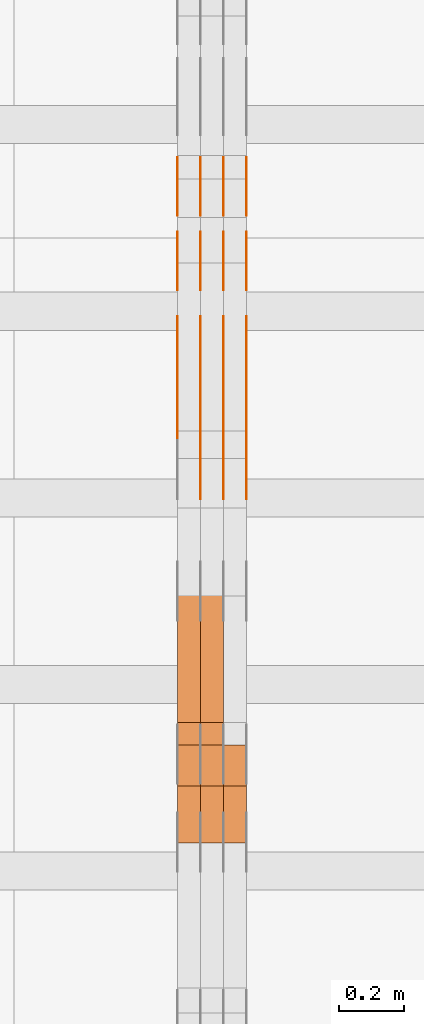
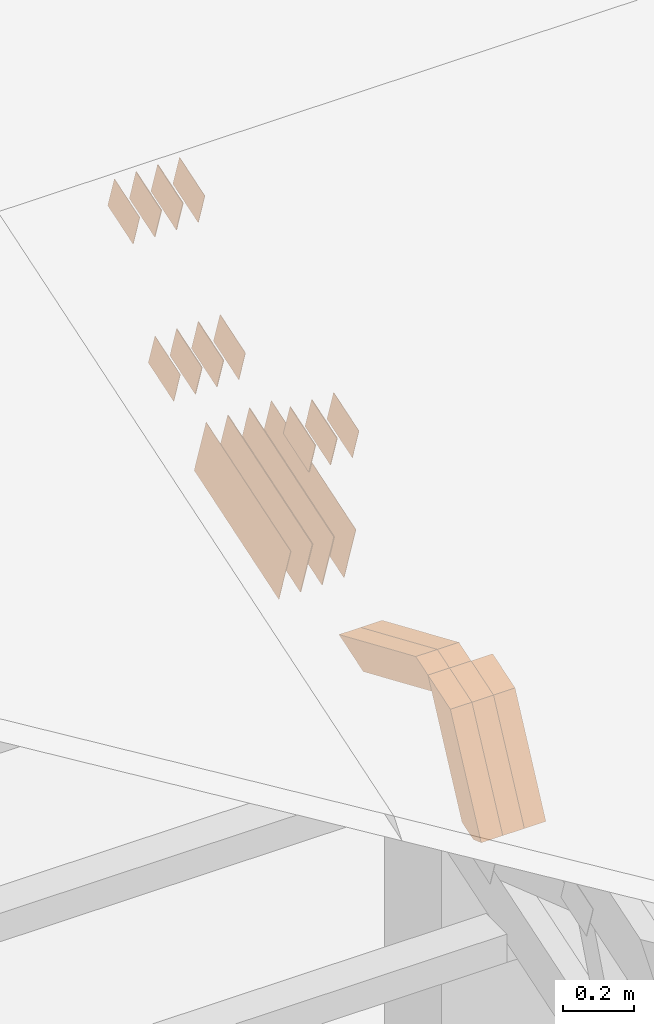
# One storey, part 132 of 385: 28 proxies.
"""IFC2X3 building model written with IfcOpenShell, lengths in millimetres."""

from ifc_helpers import new_model, entity, si_unit, converted_unit, derived_unit, direction, frame, origin, place, context, subcontext, project, spatial, polyline, outline, extrude, source, transform, mapped, material, type_object, type_shapes, element, save


model = new_model("IFC2X3")

# Units and contexts
model_context = context("Model", 3, precision=0.01, world=origin(), true_north=direction((6.12303176911189e-17, 1.0)))
body_context = subcontext(model_context, "Body", "Model", "MODEL_VIEW")
ifc_project = project(units=[si_unit("LENGTHUNIT", "METRE", prefix="MILLI"), si_unit("AREAUNIT", "SQUARE_METRE"), si_unit("VOLUMEUNIT", "CUBIC_METRE"), converted_unit("PLANEANGLEUNIT", "DEGREE", entity("IfcRatioMeasure", 0.0174532925199433), si_unit("PLANEANGLEUNIT", "RADIAN"), dimensions=[0, 0, 0, 0, 0, 0, 0]), si_unit("MASSUNIT", "GRAM", prefix="KILO"), derived_unit("MASSDENSITYUNIT", [(si_unit("MASSUNIT", "GRAM", prefix="KILO"), 1), (si_unit("LENGTHUNIT", "METRE"), -3)]), si_unit("TIMEUNIT", "SECOND"), si_unit("FREQUENCYUNIT", "HERTZ"), si_unit("THERMODYNAMICTEMPERATUREUNIT", "DEGREE_CELSIUS"), derived_unit("THERMALTRANSMITTANCEUNIT", [(si_unit("MASSUNIT", "GRAM", prefix="KILO"), 1), (si_unit("THERMODYNAMICTEMPERATUREUNIT", "KELVIN"), -1), (si_unit("TIMEUNIT", "SECOND"), -3)]), derived_unit("VOLUMETRICFLOWRATEUNIT", [(si_unit("LENGTHUNIT", "METRE"), 3), (si_unit("TIMEUNIT", "SECOND"), -1)]), si_unit("ELECTRICCURRENTUNIT", "AMPERE"), si_unit("ELECTRICVOLTAGEUNIT", "VOLT"), si_unit("POWERUNIT", "WATT"), si_unit("FORCEUNIT", "NEWTON", prefix="KILO"), si_unit("ILLUMINANCEUNIT", "LUX"), si_unit("LUMINOUSFLUXUNIT", "LUMEN"), si_unit("LUMINOUSINTENSITYUNIT", "CANDELA"), derived_unit("USERDEFINED", [(si_unit("MASSUNIT", "GRAM", prefix="KILO"), -1), (si_unit("LENGTHUNIT", "METRE"), -2), (si_unit("TIMEUNIT", "SECOND"), 3), (si_unit("LUMINOUSFLUXUNIT", "LUMEN"), 1)]), derived_unit("LINEARVELOCITYUNIT", [(si_unit("LENGTHUNIT", "METRE"), 1), (si_unit("TIMEUNIT", "SECOND"), -1)]), si_unit("PRESSUREUNIT", "PASCAL"), derived_unit("USERDEFINED", [(si_unit("LENGTHUNIT", "METRE"), -2), (si_unit("MASSUNIT", "GRAM", prefix="KILO"), 1), (si_unit("TIMEUNIT", "SECOND"), -2)])], contexts=[model_context])

# Site, building, storey
site_placement = place(None, origin())
site = spatial("IfcSite", under=ifc_project, at=site_placement, CompositionType="ELEMENT")
building_placement = place(site_placement, origin())
building = spatial("IfcBuilding", under=site, at=building_placement, CompositionType="ELEMENT")
storey_placement = place(building_placement, origin())
storey = spatial("IfcBuildingStorey", under=building, at=storey_placement, Name="Default", CompositionType="ELEMENT", Elevation=0.0)

# Proxies
ifc_material_1 = material(Name="IfcSurfaceStyle #316198")
building_element_proxy_type_1 = type_object("IfcBuildingElementProxyType", PredefinedType="NOTDEFINED", material=ifc_material_1)
shared_shape_1 = source(origin(), body_context, "Body", "SweptSolid", [
    extrude(outline(polyline([(-74.9998565677179, -60.000059685226), (74.9998794200128, -60.000059685226), (74.9998565677179, 60.000059685226), (-74.9998794200128, 60.000059685226), (-74.9998565677179, -60.000059685226)])), frame((75.0001976720505, 60.000059685226, 0.0), z_axis=(0.0, 0.0, 1.0), x_axis=(-1.0, 0.0, 0.0)), (0.0, 0.0, 1.0), 1.3),
])
type_shapes(building_element_proxy_type_1, [shared_shape_1])
proxy_1_placement = place(building_placement, frame((24386.3, 8537.53090236182, 1950.11166041942), z_axis=(-1.0, 0.0, 0.0), x_axis=(0.0, 0.951056516295124, 0.309016994375039)))
element("IfcBuildingElementProxy", 1, at=proxy_1_placement, inside=storey, type_object=building_element_proxy_type_1, material=ifc_material_1, context=body_context, shape_type="MappedRepresentation", body=[
    mapped(shared_shape_1, transform((0.0, 0.0, 0.0), scale=1.0)),
])
ifc_material_2 = material(Name="IfcSurfaceStyle #316141")
building_element_proxy_type_2 = type_object("IfcBuildingElementProxyType", PredefinedType="NOTDEFINED", material=ifc_material_2)
shared_shape_2 = source(origin(), body_context, "Body", "SweptSolid", [
    extrude(outline(polyline([(-74.9998565677179, -60.000059685226), (74.9998794200128, -60.000059685226), (74.9998565677179, 60.000059685226), (-74.9998794200128, 60.000059685226), (-74.9998565677179, -60.000059685226)])), frame((75.0001976720505, 60.000059685226, 0.0), z_axis=(0.0, 0.0, 1.0), x_axis=(-1.0, 0.0, 0.0)), (0.0, 0.0, 1.0), 1.3),
])
type_shapes(building_element_proxy_type_2, [shared_shape_2])
proxy_2_placement = place(building_placement, frame((24315.0, 8537.53090236182, 1950.11166041942), z_axis=(-1.0, 0.0, 0.0), x_axis=(0.0, 0.951056516295124, 0.309016994375039)))
element("IfcBuildingElementProxy", 2, at=proxy_2_placement, inside=storey, type_object=building_element_proxy_type_2, material=ifc_material_2, context=body_context, shape_type="MappedRepresentation", body=[
    mapped(shared_shape_2, transform((0.0, 0.0, 0.0), scale=1.0)),
])
ifc_material_3 = material(Name="IfcSurfaceStyle #316084")
building_element_proxy_type_3 = type_object("IfcBuildingElementProxyType", PredefinedType="NOTDEFINED", material=ifc_material_3)
shared_shape_3 = source(origin(), body_context, "Body", "SweptSolid", [
    extrude(outline(polyline([(-74.9998565677179, -60.000059685226), (74.9998794200128, -60.000059685226), (74.9998565677179, 60.000059685226), (-74.9998794200128, 60.000059685226), (-74.9998565677179, -60.000059685226)])), frame((75.0001976720505, 60.000059685226, 0.0), z_axis=(0.0, 0.0, 1.0), x_axis=(-1.0, 0.0, 0.0)), (0.0, 0.0, 1.0), 1.3),
])
type_shapes(building_element_proxy_type_3, [shared_shape_3])
proxy_3_placement = place(building_placement, frame((24316.3, 8537.53090236182, 1950.11166041942), z_axis=(-1.0, 0.0, 0.0), x_axis=(0.0, 0.951056516295124, 0.309016994375039)))
element("IfcBuildingElementProxy", 3, at=proxy_3_placement, inside=storey, type_object=building_element_proxy_type_3, material=ifc_material_3, context=body_context, shape_type="MappedRepresentation", body=[
    mapped(shared_shape_3, transform((0.0, 0.0, 0.0), scale=1.0)),
])
ifc_material_4 = material(Name="IfcSurfaceStyle #316027")
building_element_proxy_type_4 = type_object("IfcBuildingElementProxyType", PredefinedType="NOTDEFINED", material=ifc_material_4)
shared_shape_4 = source(origin(), body_context, "Body", "SweptSolid", [
    extrude(outline(polyline([(-74.9998565677179, -60.000059685226), (74.9998794200128, -60.000059685226), (74.9998565677179, 60.000059685226), (-74.9998794200128, 60.000059685226), (-74.9998565677179, -60.000059685226)])), frame((75.0001976720505, 60.000059685226, 0.0), z_axis=(0.0, 0.0, 1.0), x_axis=(-1.0, 0.0, 0.0)), (0.0, 0.0, 1.0), 1.29999999999999),
])
type_shapes(building_element_proxy_type_4, [shared_shape_4])
proxy_4_placement = place(building_placement, frame((24245.0, 8537.53090236182, 1950.11166041942), z_axis=(-1.0, 0.0, 0.0), x_axis=(0.0, 0.951056516295124, 0.309016994375039)))
element("IfcBuildingElementProxy", 4, at=proxy_4_placement, inside=storey, type_object=building_element_proxy_type_4, material=ifc_material_4, context=body_context, shape_type="MappedRepresentation", body=[
    mapped(shared_shape_4, transform((0.0, 0.0, 0.0), scale=1.0)),
])
ifc_material_5 = material(Name="IfcSurfaceStyle #315970")
building_element_proxy_type_5 = type_object("IfcBuildingElementProxyType", PredefinedType="NOTDEFINED", material=ifc_material_5)
shared_shape_5 = source(origin(), body_context, "Body", "SweptSolid", [
    extrude(outline(polyline([(-74.9998565677179, -60.000059685226), (74.9998794200128, -60.000059685226), (74.9998565677179, 60.000059685226), (-74.9998794200128, 60.000059685226), (-74.9998565677179, -60.000059685226)])), frame((75.0001976720505, 60.000059685226, 0.0), z_axis=(0.0, 0.0, 1.0), x_axis=(-1.0, 0.0, 0.0)), (0.0, 0.0, 1.0), 1.29999999999999),
])
type_shapes(building_element_proxy_type_5, [shared_shape_5])
proxy_5_placement = place(building_placement, frame((24246.3, 8537.53090236182, 1950.11166041942), z_axis=(-1.0, 0.0, 0.0), x_axis=(0.0, 0.951056516295124, 0.309016994375039)))
element("IfcBuildingElementProxy", 5, at=proxy_5_placement, inside=storey, type_object=building_element_proxy_type_5, material=ifc_material_5, context=body_context, shape_type="MappedRepresentation", body=[
    mapped(shared_shape_5, transform((0.0, 0.0, 0.0), scale=1.0)),
])
ifc_material_6 = material(Name="IfcSurfaceStyle #315913")
building_element_proxy_type_6 = type_object("IfcBuildingElementProxyType", PredefinedType="NOTDEFINED", material=ifc_material_6)
shared_shape_6 = source(origin(), body_context, "Body", "SweptSolid", [
    extrude(outline(polyline([(-74.9998565677179, -60.000059685226), (74.9998794200128, -60.000059685226), (74.9998565677179, 60.000059685226), (-74.9998794200128, 60.000059685226), (-74.9998565677179, -60.000059685226)])), frame((75.0001976720505, 60.000059685226, 0.0), z_axis=(0.0, 0.0, 1.0), x_axis=(-1.0, 0.0, 0.0)), (0.0, 0.0, 1.0), 1.29999999999999),
])
type_shapes(building_element_proxy_type_6, [shared_shape_6])
proxy_6_placement = place(building_placement, frame((24175.0, 8537.53090236182, 1950.11166041942), z_axis=(-1.0, 0.0, 0.0), x_axis=(0.0, 0.951056516295124, 0.309016994375039)))
element("IfcBuildingElementProxy", 6, at=proxy_6_placement, inside=storey, type_object=building_element_proxy_type_6, material=ifc_material_6, context=body_context, shape_type="MappedRepresentation", body=[
    mapped(shared_shape_6, transform((0.0, 0.0, 0.0), scale=1.0)),
])
ifc_material_7 = material(Name="IfcSurfaceStyle #315856")
building_element_proxy_type_7 = type_object("IfcBuildingElementProxyType", PredefinedType="NOTDEFINED", material=ifc_material_7)
shared_shape_7 = source(origin(), body_context, "Body", "SweptSolid", [
    extrude(outline(polyline([(-74.9998754286225, -60.0000016373515), (74.9998605591045, -60.0000016373515), (74.9998754286225, 60.0000016373515), (-74.9998605591045, 60.0000016373515), (-74.9998754286225, -60.0000016373515)])), frame((74.9998754286225, 60.0000016373515, 0.0), z_axis=(0.0, 0.0, 1.0), x_axis=(-1.0, 0.0, 0.0)), (0.0, 0.0, 1.0), 1.3),
])
type_shapes(building_element_proxy_type_7, [shared_shape_7])
proxy_7_placement = place(building_placement, frame((24386.3, 8765.47458614632, 2350.86432930304), z_axis=(-1.0, 0.0, 0.0), x_axis=(0.0, 0.951056516295154, 0.309016994374948)))
element("IfcBuildingElementProxy", 7, at=proxy_7_placement, inside=storey, type_object=building_element_proxy_type_7, material=ifc_material_7, context=body_context, shape_type="MappedRepresentation", body=[
    mapped(shared_shape_7, transform((0.0, 0.0, 0.0), scale=1.0)),
])
ifc_material_8 = material(Name="IfcSurfaceStyle #315799")
building_element_proxy_type_8 = type_object("IfcBuildingElementProxyType", PredefinedType="NOTDEFINED", material=ifc_material_8)
shared_shape_8 = source(origin(), body_context, "Body", "SweptSolid", [
    extrude(outline(polyline([(-74.9998754286225, -60.0000016373515), (74.9998605591045, -60.0000016373515), (74.9998754286225, 60.0000016373515), (-74.9998605591045, 60.0000016373515), (-74.9998754286225, -60.0000016373515)])), frame((74.9998754286225, 60.0000016373515, 0.0), z_axis=(0.0, 0.0, 1.0), x_axis=(-1.0, 0.0, 0.0)), (0.0, 0.0, 1.0), 1.3),
])
type_shapes(building_element_proxy_type_8, [shared_shape_8])
proxy_8_placement = place(building_placement, frame((24315.0, 8765.47458614632, 2350.86432930304), z_axis=(-1.0, 0.0, 0.0), x_axis=(0.0, 0.951056516295154, 0.309016994374948)))
element("IfcBuildingElementProxy", 8, at=proxy_8_placement, inside=storey, type_object=building_element_proxy_type_8, material=ifc_material_8, context=body_context, shape_type="MappedRepresentation", body=[
    mapped(shared_shape_8, transform((0.0, 0.0, 0.0), scale=1.0)),
])
ifc_material_9 = material(Name="IfcSurfaceStyle #315742")
building_element_proxy_type_9 = type_object("IfcBuildingElementProxyType", PredefinedType="NOTDEFINED", material=ifc_material_9)
shared_shape_9 = source(origin(), body_context, "Body", "SweptSolid", [
    extrude(outline(polyline([(-74.9998754286225, -60.0000016373515), (74.9998605591045, -60.0000016373515), (74.9998754286225, 60.0000016373515), (-74.9998605591045, 60.0000016373515), (-74.9998754286225, -60.0000016373515)])), frame((74.9998754286225, 60.0000016373515, 0.0), z_axis=(0.0, 0.0, 1.0), x_axis=(-1.0, 0.0, 0.0)), (0.0, 0.0, 1.0), 1.3),
])
type_shapes(building_element_proxy_type_9, [shared_shape_9])
proxy_9_placement = place(building_placement, frame((24316.3, 8765.47458614632, 2350.86432930304), z_axis=(-1.0, 0.0, 0.0), x_axis=(0.0, 0.951056516295154, 0.309016994374948)))
element("IfcBuildingElementProxy", 9, at=proxy_9_placement, inside=storey, type_object=building_element_proxy_type_9, material=ifc_material_9, context=body_context, shape_type="MappedRepresentation", body=[
    mapped(shared_shape_9, transform((0.0, 0.0, 0.0), scale=1.0)),
])
ifc_material_10 = material(Name="IfcSurfaceStyle #315685")
building_element_proxy_type_10 = type_object("IfcBuildingElementProxyType", PredefinedType="NOTDEFINED", material=ifc_material_10)
shared_shape_10 = source(origin(), body_context, "Body", "SweptSolid", [
    extrude(outline(polyline([(-74.9998754286225, -60.0000016373515), (74.9998605591045, -60.0000016373515), (74.9998754286225, 60.0000016373515), (-74.9998605591045, 60.0000016373515), (-74.9998754286225, -60.0000016373515)])), frame((74.9998754286225, 60.0000016373515, 0.0), z_axis=(0.0, 0.0, 1.0), x_axis=(-1.0, 0.0, 0.0)), (0.0, 0.0, 1.0), 1.29999999999999),
])
type_shapes(building_element_proxy_type_10, [shared_shape_10])
proxy_10_placement = place(building_placement, frame((24245.0, 8765.47458614632, 2350.86432930304), z_axis=(-1.0, 0.0, 0.0), x_axis=(0.0, 0.951056516295154, 0.309016994374948)))
element("IfcBuildingElementProxy", 10, at=proxy_10_placement, inside=storey, type_object=building_element_proxy_type_10, material=ifc_material_10, context=body_context, shape_type="MappedRepresentation", body=[
    mapped(shared_shape_10, transform((0.0, 0.0, 0.0), scale=1.0)),
])
ifc_material_11 = material(Name="IfcSurfaceStyle #315628")
building_element_proxy_type_11 = type_object("IfcBuildingElementProxyType", PredefinedType="NOTDEFINED", material=ifc_material_11)
shared_shape_11 = source(origin(), body_context, "Body", "SweptSolid", [
    extrude(outline(polyline([(-74.9998754286225, -60.0000016373515), (74.9998605591045, -60.0000016373515), (74.9998754286225, 60.0000016373515), (-74.9998605591045, 60.0000016373515), (-74.9998754286225, -60.0000016373515)])), frame((74.9998754286225, 60.0000016373515, 0.0), z_axis=(0.0, 0.0, 1.0), x_axis=(-1.0, 0.0, 0.0)), (0.0, 0.0, 1.0), 1.29999999999999),
])
type_shapes(building_element_proxy_type_11, [shared_shape_11])
proxy_11_placement = place(building_placement, frame((24246.3, 8765.47458614632, 2350.86432930304), z_axis=(-1.0, 0.0, 0.0), x_axis=(0.0, 0.951056516295154, 0.309016994374948)))
element("IfcBuildingElementProxy", 11, at=proxy_11_placement, inside=storey, type_object=building_element_proxy_type_11, material=ifc_material_11, context=body_context, shape_type="MappedRepresentation", body=[
    mapped(shared_shape_11, transform((0.0, 0.0, 0.0), scale=1.0)),
])
ifc_material_12 = material(Name="IfcSurfaceStyle #315571")
building_element_proxy_type_12 = type_object("IfcBuildingElementProxyType", PredefinedType="NOTDEFINED", material=ifc_material_12)
shared_shape_12 = source(origin(), body_context, "Body", "SweptSolid", [
    extrude(outline(polyline([(-74.9998754286225, -60.0000016373515), (74.9998605591045, -60.0000016373515), (74.9998754286225, 60.0000016373515), (-74.9998605591045, 60.0000016373515), (-74.9998754286225, -60.0000016373515)])), frame((74.9998754286225, 60.0000016373515, 0.0), z_axis=(0.0, 0.0, 1.0), x_axis=(-1.0, 0.0, 0.0)), (0.0, 0.0, 1.0), 1.29999999999999),
])
type_shapes(building_element_proxy_type_12, [shared_shape_12])
proxy_12_placement = place(building_placement, frame((24175.0, 8765.47458614632, 2350.86432930304), z_axis=(-1.0, 0.0, 0.0), x_axis=(0.0, 0.951056516295154, 0.309016994374948)))
element("IfcBuildingElementProxy", 12, at=proxy_12_placement, inside=storey, type_object=building_element_proxy_type_12, material=ifc_material_12, context=body_context, shape_type="MappedRepresentation", body=[
    mapped(shared_shape_12, transform((0.0, 0.0, 0.0), scale=1.0)),
])
ifc_material_13 = material(Name="IfcSurfaceStyle #315172")
building_element_proxy_type_13 = type_object("IfcBuildingElementProxyType", PredefinedType="NOTDEFINED", material=ifc_material_13)
shared_shape_13 = source(origin(), body_context, "Body", "SweptSolid", [
    extrude(outline(polyline([(-249.999749056184, -108.000229288163), (249.999396050782, -108.000229288163), (249.999749056184, 108.000229288163), (-249.999396050782, 108.000229288163), (-249.999749056184, -108.000229288163)])), frame((249.999841104007, 108.000229288163, 0.0), z_axis=(0.0, 0.0, 1.0), x_axis=(-1.0, 0.0, 0.0)), (0.0, 0.0, 1.0), 1.29999999999998),
])
type_shapes(building_element_proxy_type_13, [shared_shape_13])
proxy_13_placement = place(building_placement, frame((24386.3, 7917.13457673635, 1720.66532252899), z_axis=(-1.0, 0.0, 0.0), x_axis=(0.0, 0.951056516295124, 0.309016994375039)))
element("IfcBuildingElementProxy", 13, at=proxy_13_placement, inside=storey, type_object=building_element_proxy_type_13, material=ifc_material_13, context=body_context, shape_type="MappedRepresentation", body=[
    mapped(shared_shape_13, transform((0.0, 0.0, 0.0), scale=1.0)),
])
ifc_material_14 = material(Name="IfcSurfaceStyle #315115")
building_element_proxy_type_14 = type_object("IfcBuildingElementProxyType", PredefinedType="NOTDEFINED", material=ifc_material_14)
shared_shape_14 = source(origin(), body_context, "Body", "SweptSolid", [
    extrude(outline(polyline([(-249.999749056184, -108.000229288163), (249.999396050782, -108.000229288163), (249.999749056184, 108.000229288163), (-249.999396050782, 108.000229288163), (-249.999749056184, -108.000229288163)])), frame((249.999841104007, 108.000229288163, 0.0), z_axis=(0.0, 0.0, 1.0), x_axis=(-1.0, 0.0, 0.0)), (0.0, 0.0, 1.0), 1.29999999999998),
])
type_shapes(building_element_proxy_type_14, [shared_shape_14])
proxy_14_placement = place(building_placement, frame((24315.0, 7917.13457673635, 1720.66532252899), z_axis=(-1.0, 0.0, 0.0), x_axis=(0.0, 0.951056516295124, 0.309016994375039)))
element("IfcBuildingElementProxy", 14, at=proxy_14_placement, inside=storey, type_object=building_element_proxy_type_14, material=ifc_material_14, context=body_context, shape_type="MappedRepresentation", body=[
    mapped(shared_shape_14, transform((0.0, 0.0, 0.0), scale=1.0)),
])
ifc_material_15 = material(Name="IfcSurfaceStyle #315058")
building_element_proxy_type_15 = type_object("IfcBuildingElementProxyType", PredefinedType="NOTDEFINED", material=ifc_material_15)
shared_shape_15 = source(origin(), body_context, "Body", "SweptSolid", [
    extrude(outline(polyline([(-249.999749056184, -108.000229288163), (249.999396050782, -108.000229288163), (249.999749056184, 108.000229288163), (-249.999396050782, 108.000229288163), (-249.999749056184, -108.000229288163)])), frame((249.999841104007, 108.000229288163, 0.0), z_axis=(0.0, 0.0, 1.0), x_axis=(-1.0, 0.0, 0.0)), (0.0, 0.0, 1.0), 1.29999999999998),
])
type_shapes(building_element_proxy_type_15, [shared_shape_15])
proxy_15_placement = place(building_placement, frame((24316.3, 7917.13457673635, 1720.66532252899), z_axis=(-1.0, 0.0, 0.0), x_axis=(0.0, 0.951056516295124, 0.309016994375039)))
element("IfcBuildingElementProxy", 15, at=proxy_15_placement, inside=storey, type_object=building_element_proxy_type_15, material=ifc_material_15, context=body_context, shape_type="MappedRepresentation", body=[
    mapped(shared_shape_15, transform((0.0, 0.0, 0.0), scale=1.0)),
])
ifc_material_16 = material(Name="IfcSurfaceStyle #315001")
building_element_proxy_type_16 = type_object("IfcBuildingElementProxyType", PredefinedType="NOTDEFINED", material=ifc_material_16)
shared_shape_16 = source(origin(), body_context, "Body", "SweptSolid", [
    extrude(outline(polyline([(-249.999749056184, -108.000229288163), (249.999396050782, -108.000229288163), (249.999749056184, 108.000229288163), (-249.999396050782, 108.000229288163), (-249.999749056184, -108.000229288163)])), frame((249.999841104007, 108.000229288163, 0.0), z_axis=(0.0, 0.0, 1.0), x_axis=(-1.0, 0.0, 0.0)), (0.0, 0.0, 1.0), 1.29999999999997),
])
type_shapes(building_element_proxy_type_16, [shared_shape_16])
proxy_16_placement = place(building_placement, frame((24245.0, 7917.13457673635, 1720.66532252899), z_axis=(-1.0, 0.0, 0.0), x_axis=(0.0, 0.951056516295124, 0.309016994375039)))
element("IfcBuildingElementProxy", 16, at=proxy_16_placement, inside=storey, type_object=building_element_proxy_type_16, material=ifc_material_16, context=body_context, shape_type="MappedRepresentation", body=[
    mapped(shared_shape_16, transform((0.0, 0.0, 0.0), scale=1.0)),
])
ifc_material_17 = material(Name="IfcSurfaceStyle #314944")
building_element_proxy_type_17 = type_object("IfcBuildingElementProxyType", PredefinedType="NOTDEFINED", material=ifc_material_17)
shared_shape_17 = source(origin(), body_context, "Body", "SweptSolid", [
    extrude(outline(polyline([(-249.999749056184, -108.000229288163), (249.999396050782, -108.000229288163), (249.999749056184, 108.000229288163), (-249.999396050782, 108.000229288163), (-249.999749056184, -108.000229288163)])), frame((249.999841104007, 108.000229288163, 0.0), z_axis=(0.0, 0.0, 1.0), x_axis=(-1.0, 0.0, 0.0)), (0.0, 0.0, 1.0), 1.29999999999997),
])
type_shapes(building_element_proxy_type_17, [shared_shape_17])
proxy_17_placement = place(building_placement, frame((24246.3, 7917.13457673635, 1720.66532252899), z_axis=(-1.0, 0.0, 0.0), x_axis=(0.0, 0.951056516295124, 0.309016994375039)))
element("IfcBuildingElementProxy", 17, at=proxy_17_placement, inside=storey, type_object=building_element_proxy_type_17, material=ifc_material_17, context=body_context, shape_type="MappedRepresentation", body=[
    mapped(shared_shape_17, transform((0.0, 0.0, 0.0), scale=1.0)),
])
ifc_material_18 = material(Name="IfcSurfaceStyle #314887")
building_element_proxy_type_18 = type_object("IfcBuildingElementProxyType", PredefinedType="NOTDEFINED", material=ifc_material_18)
shared_shape_18 = source(origin(), body_context, "Body", "SweptSolid", [
    extrude(outline(polyline([(-249.999749056184, -108.000229288163), (249.999396050782, -108.000229288163), (249.999749056184, 108.000229288163), (-249.999396050782, 108.000229288163), (-249.999749056184, -108.000229288163)])), frame((249.999841104007, 108.000229288163, 0.0), z_axis=(0.0, 0.0, 1.0), x_axis=(-1.0, 0.0, 0.0)), (0.0, 0.0, 1.0), 1.29999999999997),
])
type_shapes(building_element_proxy_type_18, [shared_shape_18])
proxy_18_placement = place(building_placement, frame((24175.0, 7917.13457673635, 1720.66532252899), z_axis=(-1.0, 0.0, 0.0), x_axis=(0.0, 0.951056516295124, 0.309016994375039)))
element("IfcBuildingElementProxy", 18, at=proxy_18_placement, inside=storey, type_object=building_element_proxy_type_18, material=ifc_material_18, context=body_context, shape_type="MappedRepresentation", body=[
    mapped(shared_shape_18, transform((0.0, 0.0, 0.0), scale=1.0)),
])
ifc_material_19 = material(Name="IfcSurfaceStyle #301492")
building_element_proxy_type_19 = type_object("IfcBuildingElementProxyType", PredefinedType="NOTDEFINED", material=ifc_material_19)
shared_shape_19 = source(origin(), body_context, "Body", "SweptSolid", [
    extrude(outline(polyline([(-74.9998754286253, -60.0000016373506), (74.9998605591091, -60.0000016373506), (74.9998754286234, 60.0000016373506), (-74.9998605591072, 60.0000016373506), (-74.9998754286253, -60.0000016373506)])), frame((75.0007355357002, 60.0002637031812, 0.0), z_axis=(0.0, 0.0, 1.0), x_axis=(-1.0, 0.0, 0.0)), (0.0, 0.0, 1.0), 1.3),
])
type_shapes(building_element_proxy_type_19, [shared_shape_19])
proxy_19_placement = place(building_placement, frame((24386.3, 7899.79204652808, 2069.58672486412), z_axis=(-1.0, 0.0, 0.0), x_axis=(0.0, 0.951056516295154, 0.309016994374948)))
element("IfcBuildingElementProxy", 19, at=proxy_19_placement, inside=storey, type_object=building_element_proxy_type_19, material=ifc_material_19, context=body_context, shape_type="MappedRepresentation", body=[
    mapped(shared_shape_19, transform((0.0, 0.0, 0.0), scale=1.0)),
])
ifc_material_20 = material(Name="IfcSurfaceStyle #301435")
building_element_proxy_type_20 = type_object("IfcBuildingElementProxyType", PredefinedType="NOTDEFINED", material=ifc_material_20)
shared_shape_20 = source(origin(), body_context, "Body", "SweptSolid", [
    extrude(outline(polyline([(-74.9998754286253, -60.0000016373506), (74.9998605591091, -60.0000016373506), (74.9998754286234, 60.0000016373506), (-74.9998605591072, 60.0000016373506), (-74.9998754286253, -60.0000016373506)])), frame((75.0007355357002, 60.0002637031812, 0.0), z_axis=(0.0, 0.0, 1.0), x_axis=(-1.0, 0.0, 0.0)), (0.0, 0.0, 1.0), 1.3),
])
type_shapes(building_element_proxy_type_20, [shared_shape_20])
proxy_20_placement = place(building_placement, frame((24315.0, 7899.79204652808, 2069.58672486412), z_axis=(-1.0, 0.0, 0.0), x_axis=(0.0, 0.951056516295154, 0.309016994374948)))
element("IfcBuildingElementProxy", 20, at=proxy_20_placement, inside=storey, type_object=building_element_proxy_type_20, material=ifc_material_20, context=body_context, shape_type="MappedRepresentation", body=[
    mapped(shared_shape_20, transform((0.0, 0.0, 0.0), scale=1.0)),
])
ifc_material_21 = material(Name="IfcSurfaceStyle #301378")
building_element_proxy_type_21 = type_object("IfcBuildingElementProxyType", PredefinedType="NOTDEFINED", material=ifc_material_21)
shared_shape_21 = source(origin(), body_context, "Body", "SweptSolid", [
    extrude(outline(polyline([(-74.9998754286253, -60.0000016373506), (74.9998605591091, -60.0000016373506), (74.9998754286234, 60.0000016373506), (-74.9998605591072, 60.0000016373506), (-74.9998754286253, -60.0000016373506)])), frame((75.0007355357002, 60.0002637031812, 0.0), z_axis=(0.0, 0.0, 1.0), x_axis=(-1.0, 0.0, 0.0)), (0.0, 0.0, 1.0), 1.3),
])
type_shapes(building_element_proxy_type_21, [shared_shape_21])
proxy_21_placement = place(building_placement, frame((24316.3, 7899.79204652808, 2069.58672486412), z_axis=(-1.0, 0.0, 0.0), x_axis=(0.0, 0.951056516295154, 0.309016994374948)))
element("IfcBuildingElementProxy", 21, at=proxy_21_placement, inside=storey, type_object=building_element_proxy_type_21, material=ifc_material_21, context=body_context, shape_type="MappedRepresentation", body=[
    mapped(shared_shape_21, transform((0.0, 0.0, 0.0), scale=1.0)),
])
ifc_material_22 = material(Name="IfcSurfaceStyle #301321")
building_element_proxy_type_22 = type_object("IfcBuildingElementProxyType", PredefinedType="NOTDEFINED", material=ifc_material_22)
shared_shape_22 = source(origin(), body_context, "Body", "SweptSolid", [
    extrude(outline(polyline([(-74.9998754286253, -60.0000016373506), (74.9998605591091, -60.0000016373506), (74.9998754286234, 60.0000016373506), (-74.9998605591072, 60.0000016373506), (-74.9998754286253, -60.0000016373506)])), frame((75.0007355357002, 60.0002637031812, 0.0), z_axis=(0.0, 0.0, 1.0), x_axis=(-1.0, 0.0, 0.0)), (0.0, 0.0, 1.0), 1.29999999999999),
])
type_shapes(building_element_proxy_type_22, [shared_shape_22])
proxy_22_placement = place(building_placement, frame((24245.0, 7899.79204652808, 2069.58672486412), z_axis=(-1.0, 0.0, 0.0), x_axis=(0.0, 0.951056516295154, 0.309016994374948)))
element("IfcBuildingElementProxy", 22, at=proxy_22_placement, inside=storey, type_object=building_element_proxy_type_22, material=ifc_material_22, context=body_context, shape_type="MappedRepresentation", body=[
    mapped(shared_shape_22, transform((0.0, 0.0, 0.0), scale=1.0)),
])
ifc_material_23 = material(Name="IfcSurfaceStyle #301264")
building_element_proxy_type_23 = type_object("IfcBuildingElementProxyType", PredefinedType="NOTDEFINED", material=ifc_material_23)
shared_shape_23 = source(origin(), body_context, "Body", "SweptSolid", [
    extrude(outline(polyline([(-74.9998754286253, -60.0000016373506), (74.9998605591091, -60.0000016373506), (74.9998754286234, 60.0000016373506), (-74.9998605591072, 60.0000016373506), (-74.9998754286253, -60.0000016373506)])), frame((75.0007355357002, 60.0002637031812, 0.0), z_axis=(0.0, 0.0, 1.0), x_axis=(-1.0, 0.0, 0.0)), (0.0, 0.0, 1.0), 1.29999999999999),
])
type_shapes(building_element_proxy_type_23, [shared_shape_23])
proxy_23_placement = place(building_placement, frame((24246.3, 7899.79204652808, 2069.58672486412), z_axis=(-1.0, 0.0, 0.0), x_axis=(0.0, 0.951056516295154, 0.309016994374948)))
element("IfcBuildingElementProxy", 23, at=proxy_23_placement, inside=storey, type_object=building_element_proxy_type_23, material=ifc_material_23, context=body_context, shape_type="MappedRepresentation", body=[
    mapped(shared_shape_23, transform((0.0, 0.0, 0.0), scale=1.0)),
])
ifc_material_24 = material(Name="IfcSurfaceStyle #287854")
building_element_proxy_type_24 = type_object("IfcBuildingElementProxyType", Name="T1-W28 287852", PredefinedType="NOTDEFINED", material=ifc_material_24)
shared_shape_24 = source(origin(), body_context, "Body", "SweptSolid", [
    extrude(outline(polyline([(-217.926999432742, -47.5002417204892), (200.85556309928, -47.5002417204892), (198.503183549447, 8.27993157516647e-05), (144.500539771884, 47.5002003208314), (-325.932286987868, 47.5002003208314), (-217.926999432742, -47.5002417204892)])), frame((200.855855188284, 47.5002003208314, 0.0), z_axis=(0.0, 0.0, 1.0), x_axis=(-1.0, 0.0, 0.0)), (0.0, 0.0, 1.0), 70.0),
])
type_shapes(building_element_proxy_type_24, [shared_shape_24])
proxy_24_placement = place(building_placement, frame((24315.0, 7164.46308589723, 1806.71154838415), z_axis=(-1.0, 0.0, 0.0), x_axis=(0.0, 0.918207947119617, -0.396098681954861)))
element("IfcBuildingElementProxy", 24, at=proxy_24_placement, inside=storey, type_object=building_element_proxy_type_24, material=ifc_material_24, Name="T1-W28", context=body_context, shape_type="MappedRepresentation", body=[
    mapped(shared_shape_24, transform((0.0, 0.0, 0.0), scale=1.0)),
])
ifc_material_25 = material(Name="IfcSurfaceStyle #287788")
building_element_proxy_type_25 = type_object("IfcBuildingElementProxyType", Name="T1-W28 287786", PredefinedType="NOTDEFINED", material=ifc_material_25)
shared_shape_25 = source(origin(), body_context, "Body", "SweptSolid", [
    extrude(outline(polyline([(-217.926999432742, -47.5002417204892), (200.85556309928, -47.5002417204892), (198.503183549447, 8.27993157516647e-05), (144.500539771884, 47.5002003208314), (-325.932286987868, 47.5002003208314), (-217.926999432742, -47.5002417204892)])), frame((200.855855188284, 47.5002003208314, 0.0), z_axis=(0.0, 0.0, 1.0), x_axis=(-1.0, 0.0, 0.0)), (0.0, 0.0, 1.0), 70.0),
])
type_shapes(building_element_proxy_type_25, [shared_shape_25])
proxy_25_placement = place(building_placement, frame((24245.0, 7164.46308589723, 1806.71154838415), z_axis=(-1.0, 0.0, 0.0), x_axis=(0.0, 0.918207947119617, -0.396098681954861)))
element("IfcBuildingElementProxy", 25, at=proxy_25_placement, inside=storey, type_object=building_element_proxy_type_25, material=ifc_material_25, Name="T1-W28", context=body_context, shape_type="MappedRepresentation", body=[
    mapped(shared_shape_25, transform((0.0, 0.0, 0.0), scale=1.0)),
])
ifc_material_26 = material(Name="IfcSurfaceStyle #287524")
building_element_proxy_type_26 = type_object("IfcBuildingElementProxyType", Name="T1-W38 287522", PredefinedType="NOTDEFINED", material=ifc_material_26)
shared_shape_26 = source(origin(), body_context, "Body", "SweptSolid", [
    extrude(outline(polyline([(-298.027186733919, -47.5000251939178), (135.138415004037, -47.5000251939178), (181.282052802132, 0.000918984287993996), (187.347601017465, 47.4995657017738), (-205.740882089715, 47.4995657017739), (-298.027186733919, -47.5000251939178)])), frame((187.347846776827, 47.5001085012031, 0.0), z_axis=(0.0, 0.0, 1.0), x_axis=(-1.0, 0.0, 0.0)), (0.0, 0.0, 1.0), 70.0),
])
type_shapes(building_element_proxy_type_26, [shared_shape_26])
proxy_26_placement = place(building_placement, frame((24385.0, 6848.47987320449, 1368.44362234215), z_axis=(-1.0, 0.0, 0.0), x_axis=(0.0, 0.441034274474743, 0.897490261082836)))
element("IfcBuildingElementProxy", 26, at=proxy_26_placement, inside=storey, type_object=building_element_proxy_type_26, material=ifc_material_26, Name="T1-W38", context=body_context, shape_type="MappedRepresentation", body=[
    mapped(shared_shape_26, transform((0.0, 0.0, 0.0), scale=1.0)),
])
ifc_material_27 = material(Name="IfcSurfaceStyle #287458")
building_element_proxy_type_27 = type_object("IfcBuildingElementProxyType", Name="T1-W38 287456", PredefinedType="NOTDEFINED", material=ifc_material_27)
shared_shape_27 = source(origin(), body_context, "Body", "SweptSolid", [
    extrude(outline(polyline([(-298.027186733919, -47.5000251939178), (135.138415004037, -47.5000251939178), (181.282052802132, 0.000918984287993996), (187.347601017465, 47.4995657017738), (-205.740882089715, 47.4995657017739), (-298.027186733919, -47.5000251939178)])), frame((187.347846776827, 47.5001085012031, 0.0), z_axis=(0.0, 0.0, 1.0), x_axis=(-1.0, 0.0, 0.0)), (0.0, 0.0, 1.0), 70.0),
])
type_shapes(building_element_proxy_type_27, [shared_shape_27])
proxy_27_placement = place(building_placement, frame((24315.0, 6848.47987320449, 1368.44362234215), z_axis=(-1.0, 0.0, 0.0), x_axis=(0.0, 0.441034274474743, 0.897490261082836)))
element("IfcBuildingElementProxy", 27, at=proxy_27_placement, inside=storey, type_object=building_element_proxy_type_27, material=ifc_material_27, Name="T1-W38", context=body_context, shape_type="MappedRepresentation", body=[
    mapped(shared_shape_27, transform((0.0, 0.0, 0.0), scale=1.0)),
])
ifc_material_28 = material(Name="IfcSurfaceStyle #287392")
building_element_proxy_type_28 = type_object("IfcBuildingElementProxyType", Name="T1-W38 287390", PredefinedType="NOTDEFINED", material=ifc_material_28)
shared_shape_28 = source(origin(), body_context, "Body", "SweptSolid", [
    extrude(outline(polyline([(-298.027186733919, -47.5000251939178), (135.138415004037, -47.5000251939178), (181.282052802132, 0.000918984287993996), (187.347601017465, 47.4995657017738), (-205.740882089715, 47.4995657017739), (-298.027186733919, -47.5000251939178)])), frame((187.347846776827, 47.5001085012031, 0.0), z_axis=(0.0, 0.0, 1.0), x_axis=(-1.0, 0.0, 0.0)), (0.0, 0.0, 1.0), 70.0),
])
type_shapes(building_element_proxy_type_28, [shared_shape_28])
proxy_28_placement = place(building_placement, frame((24245.0, 6848.47987320449, 1368.44362234215), z_axis=(-1.0, 0.0, 0.0), x_axis=(0.0, 0.441034274474743, 0.897490261082836)))
element("IfcBuildingElementProxy", 28, at=proxy_28_placement, inside=storey, type_object=building_element_proxy_type_28, material=ifc_material_28, Name="T1-W38", context=body_context, shape_type="MappedRepresentation", body=[
    mapped(shared_shape_28, transform((0.0, 0.0, 0.0), scale=1.0)),
])

save(model, "model.ifc")
